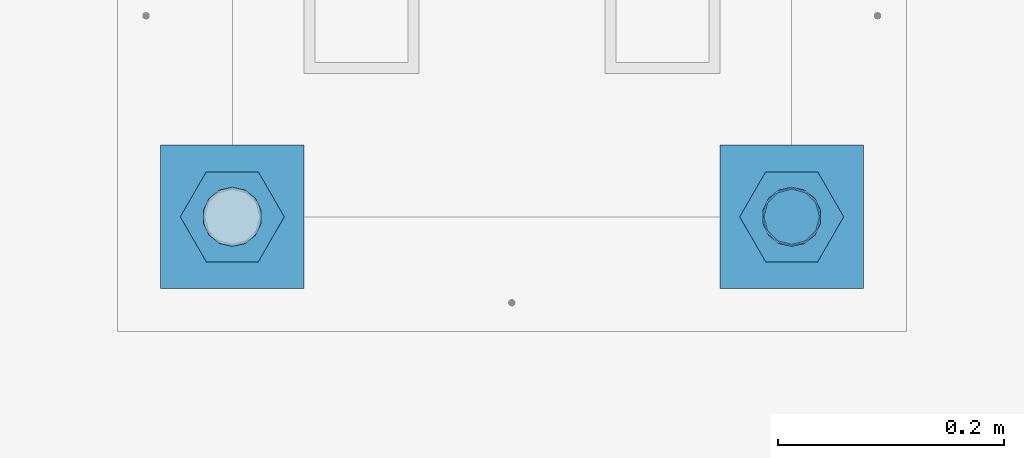
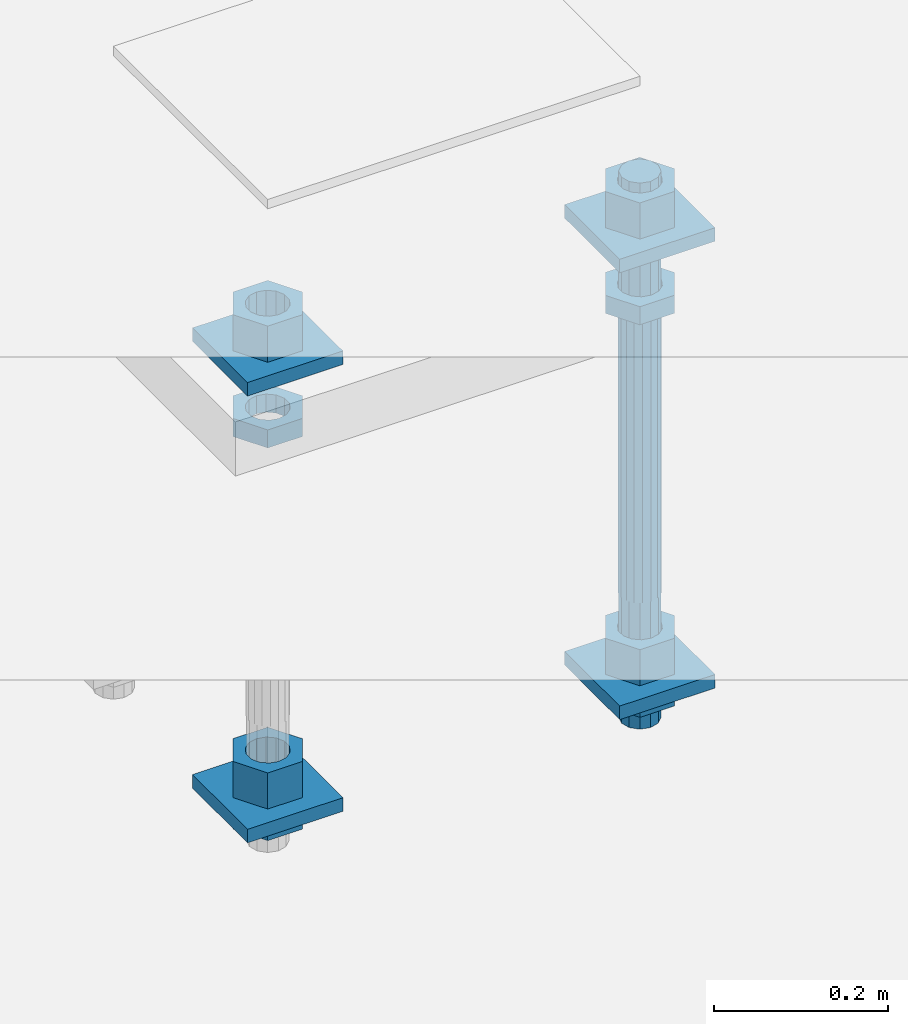
# One storey, part 2711 of 3843: 13 beams, 1 element without a shape of its own.
"""IFC2X3 building model written with IfcOpenShell, lengths in millimetres."""

import ifcopenshell
import ifcopenshell.guid

model = None  # the IFC model being written
_history = None  # IfcOwnerHistory: only IFC2X3 demands one
_inside = {}  # id of a spatial element -> (the spatial element, [elements in it])
_under = {}  # id of a project, library or spatial element -> (it, [spatial elements below it])
_declared = {}  # id of a project -> (the project, [libraries it declares])
_typed = {}  # id of a type object -> (the type object, [elements of that type])
_made_of = {}  # id of a material, layer set ... -> (it, [elements and type objects made of it])


def new_model(schema):
    """Start an empty IFC model of exactly this schema.

    Asked for "IFC4X3", IfcOpenShell would pick the latest addendum, in which some entities
    have other attributes; the version numbers below select the first issue.
    IFC2X3 requires an IfcOwnerHistory on every rooted entity: one is made here for all.
    """
    global model, _history
    if schema == "IFC4X3":
        model = ifcopenshell.file(schema_version=(4, 3, 0, 0))
    else:
        model = ifcopenshell.file(schema=schema)
    _inside.clear()
    _under.clear()
    _declared.clear()
    _typed.clear()
    _made_of.clear()
    _history = None
    if model.schema == "IFC2X3":
        org = make("IfcOrganization", Name="unknown")
        user = make(
            "IfcPersonAndOrganization",
            ThePerson=make("IfcPerson", FamilyName="unknown"),
            TheOrganization=org,
        )
        app = make(
            "IfcApplication",
            ApplicationDeveloper=org,
            Version="unknown",
            ApplicationFullName="unknown",
            ApplicationIdentifier="unknown",
        )
        _history = make(
            "IfcOwnerHistory",
            OwningUser=user,
            OwningApplication=app,
            ChangeAction="ADDED",
            CreationDate=0,
        )
    return model


def make(cls, **values):
    """One entity of the class cls with the attributes given. An attribute that is None is left unset."""
    return model.create_entity(
        cls, **{name: value for name, value in values.items() if value is not None}
    )


def rooted(cls, **values):
    """An entity with a GlobalId (a new one), such as an element, a storey or a relation."""
    return make(cls, GlobalId=ifcopenshell.guid.new(), OwnerHistory=_history, **values)


def si_unit(unit_type, name, prefix=None):
    """IfcSIUnit, for example si_unit("LENGTHUNIT", "METRE", prefix="MILLI")."""
    return make("IfcSIUnit", UnitType=unit_type, Prefix=prefix, Name=name)


def assignment(units):
    """IfcUnitAssignment: the units of a project."""
    return None if units is None else make("IfcUnitAssignment", Units=units)


def point(xyz):
    """IfcCartesianPoint."""
    return None if xyz is None else make("IfcCartesianPoint", Coordinates=xyz)


def direction(xyz):
    """IfcDirection."""
    return None if xyz is None else make("IfcDirection", DirectionRatios=xyz)


def frame(location, z_axis=None, x_axis=None):
    """IfcAxis2Placement3D, a coordinate frame: its origin and axes. An axis left out is left unset."""
    return make(
        "IfcAxis2Placement3D",
        Location=point(location),
        Axis=direction(z_axis),
        RefDirection=direction(x_axis),
    )


def origin_with_axes():
    """The frame at (0, 0, 0) with the z axis (0, 0, 1) and the x axis (1, 0, 0) written out."""
    return frame((0.0, 0.0, 0.0), z_axis=(0.0, 0.0, 1.0), x_axis=(1.0, 0.0, 0.0))


def place(relative_to, where):
    """IfcLocalPlacement: puts the frame where relative to a parent placement (None: the world)."""
    return make(
        "IfcLocalPlacement", PlacementRelTo=relative_to, RelativePlacement=where
    )


def context(
    kind, dimensions, precision=None, world=None, true_north=None, identifier=None
):
    """IfcGeometricRepresentationContext, for example the 3D "Model" context."""
    return make(
        "IfcGeometricRepresentationContext",
        ContextIdentifier=identifier,
        ContextType=kind,
        CoordinateSpaceDimension=dimensions,
        Precision=precision,
        WorldCoordinateSystem=world,
        TrueNorth=true_north,
    )


def subcontext(parent, identifier, kind, view, scale=None):
    """IfcGeometricRepresentationSubContext, for example "Body" below "Model"."""
    return make(
        "IfcGeometricRepresentationSubContext",
        ContextIdentifier=identifier,
        ContextType=kind,
        ParentContext=parent,
        TargetScale=scale,
        TargetView=view,
    )


def project(units=None, contexts=None):
    """IfcProject with its units and contexts."""
    return rooted(
        "IfcProject",
        Name="project",
        RepresentationContexts=contexts,
        UnitsInContext=assignment(units),
    )


def spatial(cls, under=None, at=None, **own):
    """A site, building, storey or space (cls), placed at a placement, below another one or the project."""
    s = rooted(cls, ObjectPlacement=at, **own)
    if under is not None:
        _under.setdefault(under.id(), (under, []))[1].append(s)
    return s


def faces_of(points, faces, orient=None, outer=None):
    """IfcFace entities. A face is a list of loops; a loop is a list of indices into points, from 0.

    orient and outer hold one flag for each loop. By default every Orientation is true, the
    first loop of a face is its IfcFaceOuterBound and the others are IfcFaceBound.
    """
    made = []
    for i, loops in enumerate(faces):
        bounds = []
        for j, loop in enumerate(loops):
            is_outer = j == 0 if outer is None else outer[i][j]
            bounds.append(
                make(
                    "IfcFaceOuterBound" if is_outer else "IfcFaceBound",
                    Bound=make("IfcPolyLoop", Polygon=[points[k] for k in loop]),
                    Orientation=True if orient is None else orient[i][j],
                )
            )
        made.append(make("IfcFace", Bounds=bounds))
    return made


def faceted_brep(points, faces, orient=None, outer=None, voids=None):
    """IfcFacetedBrep: a solid bounded by flat faces; with voids (closed shells), ...WithVoids."""
    shared = [point(p) for p in points]
    hull = make("IfcClosedShell", CfsFaces=faces_of(shared, faces, orient, outer))
    if voids is None:
        return make("IfcFacetedBrep", Outer=hull)
    return make(
        "IfcFacetedBrepWithVoids",
        Outer=hull,
        Voids=[
            make(cls, CfsFaces=faces_of(shared, fs, o, b)) for cls, fs, o, b in voids
        ],
    )


def shape(context_of_items, identifier, shape_type, items):
    """IfcShapeRepresentation: the items that make up one representation, for example the "Body"."""
    return make(
        "IfcShapeRepresentation",
        ContextOfItems=context_of_items,
        RepresentationIdentifier=identifier,
        RepresentationType=shape_type,
        Items=items,
    )


def material(Name=None, Category=None):
    """IfcMaterial."""
    return make("IfcMaterial", Name=Name, Category=Category)


def made_of(thing, what):
    """Note that an element or type object is made of a material, layer set ...; save() writes the relation."""
    if what is not None:
        _made_of.setdefault(what.id(), (what, []))[1].append(thing)
    return thing


def type_object(cls, material=None, **own):
    """A type object (cls), such as IfcWallType, which elements share."""
    return made_of(rooted(cls, **own), material)


def element(
    cls,
    number,
    at=None,
    inside=None,
    cuts=None,
    type_object=None,
    material=None,
    context=None,
    identifier="Body",
    shape_type=None,
    held_by="IfcProductDefinitionShape",
    body=None,
    shapes=None,
    **own,
):
    """One element of the class cls, such as IfcWall. Its Tag is "e" and its number.

    at: its placement. inside: the storey or other place that contains it. cuts: it is an
    opening in that element (IfcRelVoidsElement). A single representation is given by context,
    identifier, shape_type and body (its items); several are given by shapes. held_by: the class
    of the entity that holds the representations. save() writes the other relations.
    """
    e = rooted(cls, Tag="e%d" % number, ObjectPlacement=at, **own)
    if body is not None:
        shapes = [shape(context, identifier, shape_type, body)]
    if shapes is not None:
        e.Representation = make(held_by, Representations=shapes)
    if inside is not None:
        _inside.setdefault(inside.id(), (inside, []))[1].append(e)
    if cuts is not None:
        rooted(
            "IfcRelVoidsElement", RelatingBuildingElement=cuts, RelatedOpeningElement=e
        )
    if type_object is not None:
        _typed.setdefault(type_object.id(), (type_object, []))[1].append(e)
    return made_of(e, material)


def aggregate(whole, parts):
    """IfcRelAggregates: a whole, such as a stair, and the parts it consists of."""
    return rooted("IfcRelAggregates", RelatingObject=whole, RelatedObjects=parts)


def save(model, path):
    """Write the relations noted so far, then the file.

    IfcRelAggregates (storeys below a building ...), IfcRelContainedInSpatialStructure (elements
    in a storey), IfcRelDefinesByType, IfcRelAssociatesMaterial and IfcRelDeclares: one each for
    every whole, place, type object, material and project.
    """
    for whole, parts in _under.values():
        aggregate(whole, parts)
    for where, things in _inside.values():
        rooted(
            "IfcRelContainedInSpatialStructure",
            RelatedElements=things,
            RelatingStructure=where,
        )
    for kind, things in _typed.values():
        rooted("IfcRelDefinesByType", RelatedObjects=things, RelatingType=kind)
    for what, things in _made_of.values():
        rooted("IfcRelAssociatesMaterial", RelatedObjects=things, RelatingMaterial=what)
    for by, libraries in _declared.values():
        rooted("IfcRelDeclares", RelatingContext=by, RelatedDefinitions=libraries)
    model.write(path)


model = new_model("IFC2X3")

# Units and contexts
model_context = context("Model", 3, precision=1e-05, world=origin_with_axes())
body_context = subcontext(model_context, "Body", "Model", "MODEL_VIEW")
ifc_project = project(units=[si_unit("LENGTHUNIT", "METRE", prefix="MILLI"), si_unit("AREAUNIT", "SQUARE_METRE"), si_unit("VOLUMEUNIT", "CUBIC_METRE"), si_unit("MASSUNIT", "GRAM", prefix="KILO"), si_unit("TIMEUNIT", "SECOND"), si_unit("PLANEANGLEUNIT", "RADIAN"), si_unit("SOLIDANGLEUNIT", "STERADIAN"), si_unit("THERMODYNAMICTEMPERATUREUNIT", "DEGREE_CELSIUS"), si_unit("LUMINOUSINTENSITYUNIT", "LUMEN")], contexts=[model_context])

# Site, building, storey
site_placement = place(None, origin_with_axes())
site = spatial("IfcSite", under=ifc_project, at=site_placement, CompositionType="ELEMENT")
building_placement = place(site_placement, origin_with_axes())
building = spatial("IfcBuilding", under=site, at=building_placement, Name="Undefined", CompositionType="ELEMENT")
storey_placement = place(building_placement, origin_with_axes())
storey = spatial("IfcBuildingStorey", under=building, at=storey_placement, Name="Undefined", CompositionType="ELEMENT", Elevation=0.0)

# Assembly, beams
assembly_placement = place(storey_placement, origin_with_axes())
assembly = element("IfcElementAssembly", 1, at=assembly_placement, inside=storey, Name="TEMPLATE", AssemblyPlace="NOTDEFINED", PredefinedType="RIGID_FRAME")
ifc_material_1 = material(Name="STEEL/A572-50")
beam_type_1 = type_object("IfcBeamType", PredefinedType="NOTDEFINED")
beam_1_placement = place(assembly_placement, frame((105403.65, 48615.5999984741, 29873.575), z_axis=(-1.0, 0.0, 0.0), x_axis=(0.0, -1.0, 0.0)))
beam_1 = element("IfcBeam", 2, at=beam_1_placement, type_object=beam_type_1, material=ifc_material_1, Name="WASHER_PLATE", context=body_context, shape_type="Brep", body=[
    faceted_brep([(0.0, 9.52500000000146, -63.5), (0.0, 9.52500000000146, 63.5), (127.0, 9.52500000000146, 63.5), (127.0, 9.52500000000146, -63.5), (0.0, -9.52500000000146, 63.5), (127.0, -9.52500000000146, 63.5), (0.0, -9.52500000000146, -63.5), (127.0, -9.52500000000146, -63.5)], [[[0, 1, 2, 3]], [[1, 4, 5, 2]], [[4, 6, 7, 5]], [[6, 0, 3, 7]], [[5, 7, 3, 2]], [[6, 4, 1, 0]]]),
])
beam_2_placement = place(assembly_placement, frame((104908.35, 48615.5999984741, 29873.575), z_axis=(-1.0, 0.0, 0.0), x_axis=(0.0, -1.0, 0.0)))
beam_2 = element("IfcBeam", 3, at=beam_2_placement, type_object=beam_type_1, material=ifc_material_1, Name="WASHER_PLATE", context=body_context, shape_type="Brep", body=[
    faceted_brep([(0.0, 9.52500000000146, -63.5), (0.0, 9.52500000000146, 63.5), (127.0, 9.52500000000146, 63.5), (127.0, 9.52500000000146, -63.5), (0.0, -9.52500000000146, 63.5), (127.0, -9.52500000000146, 63.5), (0.0, -9.52500000000146, -63.5), (127.0, -9.52500000000146, -63.5)], [[[0, 1, 2, 3]], [[1, 4, 5, 2]], [[4, 6, 7, 5]], [[6, 0, 3, 7]], [[5, 7, 3, 2]], [[6, 4, 1, 0]]]),
])
beam_3_placement = place(assembly_placement, frame((105403.65, 48615.5999984741, 29244.925), z_axis=(-1.0, 0.0, 0.0), x_axis=(0.0, -1.0, 0.0)))
beam_3 = element("IfcBeam", 4, at=beam_3_placement, type_object=beam_type_1, material=ifc_material_1, Name="WASHER_PLATE", context=body_context, shape_type="Brep", body=[
    faceted_brep([(0.0, 9.52500000000146, -63.5), (0.0, 9.52500000000146, 63.5), (127.0, 9.52500000000146, 63.5), (127.0, 9.52500000000146, -63.5), (0.0, -9.52500000000146, 63.5), (127.0, -9.52500000000146, 63.5), (0.0, -9.52500000000146, -63.5), (127.0, -9.52500000000146, -63.5)], [[[0, 1, 2, 3]], [[1, 4, 5, 2]], [[4, 6, 7, 5]], [[6, 0, 3, 7]], [[5, 7, 3, 2]], [[6, 4, 1, 0]]]),
])
beam_4_placement = place(assembly_placement, frame((104908.35, 48615.5999984741, 29244.925), z_axis=(-1.0, 0.0, 0.0), x_axis=(0.0, -1.0, 0.0)))
beam_4 = element("IfcBeam", 5, at=beam_4_placement, type_object=beam_type_1, material=ifc_material_1, Name="WASHER_PLATE", context=body_context, shape_type="Brep", body=[
    faceted_brep([(0.0, 9.52500000000146, -63.5), (0.0, 9.52500000000146, 63.5), (127.0, 9.52500000000146, 63.5), (127.0, 9.52500000000146, -63.5), (0.0, -9.52500000000146, 63.5), (127.0, -9.52500000000146, 63.5), (0.0, -9.52500000000146, -63.5), (127.0, -9.52500000000146, -63.5)], [[[0, 1, 2, 3]], [[1, 4, 5, 2]], [[4, 6, 7, 5]], [[6, 0, 3, 7]], [[5, 7, 3, 2]], [[6, 4, 1, 0]]]),
])
ifc_material_2 = material(Name="STEEL/A36")
beam_type_2 = type_object("IfcBeamType", Name="2_HALF_NUT", PredefinedType="NOTDEFINED")
beam_5_placement = place(assembly_placement, frame((105403.65, 48552.0999984741, 29787.85), z_axis=(0.0, -1.0, 0.0), x_axis=(0.0, 0.0, -1.0)))
beam_5 = element("IfcBeam", 6, at=beam_5_placement, type_object=beam_type_2, material=ifc_material_2, Name="NUT", ObjectType="2_HALF_NUT", context=body_context, shape_type="Brep", body=[
    faceted_brep([(0.0, -46.0369987487793, 0.0), (0.0, -23.0184993743896, -39.869213104248), (25.4000000000015, -23.0184993743896, -39.869213104248), (25.4000000000015, -46.0369987487793, 0.0), (0.0, 23.0184993743896, -39.869213104248), (25.4000000000015, 23.0184993743896, -39.869213104248), (0.0, 46.0369987487793, 0.0), (25.4000000000015, 46.0369987487793, 0.0), (0.0, 23.0184993743896, 39.869213104248), (25.4000000000015, 23.0184993743896, 39.869213104248), (0.0, -23.0184993743896, 39.869213104248), (25.4000000000015, -23.0184993743896, 39.869213104248), (0.0, 0.0, 26.1940002441406), (0.0, 11.3650617044477, 23.5999013092805), (25.4000000000015, 11.3650617044477, 23.5999013092805), (25.4000000000015, 0.0, 26.1940002441406), (0.0, 20.4791109456419, 16.3316083006721), (25.4000000000015, 20.4791109456419, 16.3316083006721), (0.0, 25.5370200498292, 5.82867859874386), (25.4000000000015, 25.5370200498292, 5.82867859874386), (0.0, 25.5370200498292, -5.82867859874386), (25.4000000000015, 25.5370200498292, -5.82867859874386), (0.0, 20.4791109456419, -16.3316083006721), (25.4000000000015, 20.4791109456419, -16.3316083006721), (0.0, 11.3650617044477, -23.5999013092805), (25.4000000000015, 11.3650617044477, -23.5999013092805), (0.0, 0.0, -26.1940002441406), (25.4000000000015, 0.0, -26.1940002441406), (0.0, -11.3650617044477, -23.5999013092805), (25.4000000000015, -11.3650617044477, -23.5999013092805), (0.0, -20.4791109456419, -16.3316083006721), (25.4000000000015, -20.4791109456419, -16.3316083006721), (0.0, -25.5370200498292, -5.82867859874386), (25.4000000000015, -25.5370200498292, -5.82867859874386), (0.0, -25.5370200498292, 5.82867859874386), (25.4000000000015, -25.5370200498292, 5.82867859874386), (0.0, -20.4791109456419, 16.3316083006721), (25.4000000000015, -20.4791109456419, 16.3316083006721), (0.0, -11.3650617044477, 23.5999013092805), (25.4000000000015, -11.3650617044477, 23.5999013092805)], [[[0, 1, 2, 3]], [[1, 4, 5, 2]], [[4, 6, 7, 5]], [[6, 8, 9, 7]], [[8, 10, 11, 9]], [[10, 0, 3, 11]], [[12, 13, 14, 15]], [[13, 16, 17, 14]], [[16, 18, 19, 17]], [[18, 20, 21, 19]], [[20, 22, 23, 21]], [[22, 24, 25, 23]], [[24, 26, 27, 25]], [[26, 28, 29, 27]], [[28, 30, 31, 29]], [[30, 32, 33, 31]], [[32, 34, 35, 33]], [[34, 36, 37, 35]], [[36, 38, 39, 37]], [[38, 12, 15, 39]], [[5, 7, 9, 11, 3, 2], [17, 19, 21, 23, 25, 27, 29, 31, 33, 35, 37, 39, 15, 14]], [[10, 8, 6, 4, 1, 0], [38, 36, 34, 32, 30, 28, 26, 24, 22, 20, 18, 16, 13, 12]]]),
])
beam_6_placement = place(assembly_placement, frame((105403.65, 48552.0999984741, 29235.4), z_axis=(0.0, -1.0, 0.0), x_axis=(0.0, 0.0, -1.0)))
beam_6 = element("IfcBeam", 7, at=beam_6_placement, type_object=beam_type_2, material=ifc_material_2, Name="NUT", ObjectType="2_HALF_NUT", context=body_context, shape_type="Brep", body=[
    faceted_brep([(0.0, -46.0369987487793, 0.0), (0.0, -23.0184993743896, -39.869213104248), (25.4000000000015, -23.0184993743896, -39.869213104248), (25.4000000000015, -46.0369987487793, 0.0), (0.0, 23.0184993743896, -39.869213104248), (25.4000000000015, 23.0184993743896, -39.869213104248), (0.0, 46.0369987487793, 0.0), (25.4000000000015, 46.0369987487793, 0.0), (0.0, 23.0184993743896, 39.869213104248), (25.4000000000015, 23.0184993743896, 39.869213104248), (0.0, -23.0184993743896, 39.869213104248), (25.4000000000015, -23.0184993743896, 39.869213104248), (0.0, 0.0, 26.1940002441406), (0.0, 11.3650617044477, 23.5999013092805), (25.4000000000015, 11.3650617044477, 23.5999013092805), (25.4000000000015, 0.0, 26.1940002441406), (0.0, 20.4791109456419, 16.3316083006721), (25.4000000000015, 20.4791109456419, 16.3316083006721), (0.0, 25.5370200498292, 5.82867859874386), (25.4000000000015, 25.5370200498292, 5.82867859874386), (0.0, 25.5370200498292, -5.82867859874386), (25.4000000000015, 25.5370200498292, -5.82867859874386), (0.0, 20.4791109456419, -16.3316083006721), (25.4000000000015, 20.4791109456419, -16.3316083006721), (0.0, 11.3650617044477, -23.5999013092805), (25.4000000000015, 11.3650617044477, -23.5999013092805), (0.0, 0.0, -26.1940002441406), (25.4000000000015, 0.0, -26.1940002441406), (0.0, -11.3650617044477, -23.5999013092805), (25.4000000000015, -11.3650617044477, -23.5999013092805), (0.0, -20.4791109456419, -16.3316083006721), (25.4000000000015, -20.4791109456419, -16.3316083006721), (0.0, -25.5370200498292, -5.82867859874386), (25.4000000000015, -25.5370200498292, -5.82867859874386), (0.0, -25.5370200498292, 5.82867859874386), (25.4000000000015, -25.5370200498292, 5.82867859874386), (0.0, -20.4791109456419, 16.3316083006721), (25.4000000000015, -20.4791109456419, 16.3316083006721), (0.0, -11.3650617044477, 23.5999013092805), (25.4000000000015, -11.3650617044477, 23.5999013092805)], [[[0, 1, 2, 3]], [[1, 4, 5, 2]], [[4, 6, 7, 5]], [[6, 8, 9, 7]], [[8, 10, 11, 9]], [[10, 0, 3, 11]], [[12, 13, 14, 15]], [[13, 16, 17, 14]], [[16, 18, 19, 17]], [[18, 20, 21, 19]], [[20, 22, 23, 21]], [[22, 24, 25, 23]], [[24, 26, 27, 25]], [[26, 28, 29, 27]], [[28, 30, 31, 29]], [[30, 32, 33, 31]], [[32, 34, 35, 33]], [[34, 36, 37, 35]], [[36, 38, 39, 37]], [[38, 12, 15, 39]], [[5, 7, 9, 11, 3, 2], [17, 19, 21, 23, 25, 27, 29, 31, 33, 35, 37, 39, 15, 14]], [[10, 8, 6, 4, 1, 0], [38, 36, 34, 32, 30, 28, 26, 24, 22, 20, 18, 16, 13, 12]]]),
])
beam_7_placement = place(assembly_placement, frame((104908.35, 48552.0999984741, 29787.85), z_axis=(0.0, -1.0, 0.0), x_axis=(0.0, 0.0, -1.0)))
beam_7 = element("IfcBeam", 8, at=beam_7_placement, type_object=beam_type_2, material=ifc_material_2, Name="NUT", ObjectType="2_HALF_NUT", context=body_context, shape_type="Brep", body=[
    faceted_brep([(0.0, -46.0369987487793, 0.0), (0.0, -23.0184993743896, -39.869213104248), (25.4000000000015, -23.0184993743896, -39.869213104248), (25.4000000000015, -46.0369987487793, 0.0), (0.0, 23.0184993743896, -39.869213104248), (25.4000000000015, 23.0184993743896, -39.869213104248), (0.0, 46.0369987487793, 0.0), (25.4000000000015, 46.0369987487793, 0.0), (0.0, 23.0184993743896, 39.869213104248), (25.4000000000015, 23.0184993743896, 39.869213104248), (0.0, -23.0184993743896, 39.869213104248), (25.4000000000015, -23.0184993743896, 39.869213104248), (0.0, 0.0, 26.1940002441406), (0.0, 11.3650617044477, 23.5999013092805), (25.4000000000015, 11.3650617044477, 23.5999013092805), (25.4000000000015, 0.0, 26.1940002441406), (0.0, 20.4791109456419, 16.3316083006721), (25.4000000000015, 20.4791109456419, 16.3316083006721), (0.0, 25.5370200498292, 5.82867859874386), (25.4000000000015, 25.5370200498292, 5.82867859874386), (0.0, 25.5370200498292, -5.82867859874386), (25.4000000000015, 25.5370200498292, -5.82867859874386), (0.0, 20.4791109456419, -16.3316083006721), (25.4000000000015, 20.4791109456419, -16.3316083006721), (0.0, 11.3650617044477, -23.5999013092805), (25.4000000000015, 11.3650617044477, -23.5999013092805), (0.0, 0.0, -26.1940002441406), (25.4000000000015, 0.0, -26.1940002441406), (0.0, -11.3650617044477, -23.5999013092805), (25.4000000000015, -11.3650617044477, -23.5999013092805), (0.0, -20.4791109456419, -16.3316083006721), (25.4000000000015, -20.4791109456419, -16.3316083006721), (0.0, -25.5370200498292, -5.82867859874386), (25.4000000000015, -25.5370200498292, -5.82867859874386), (0.0, -25.5370200498292, 5.82867859874386), (25.4000000000015, -25.5370200498292, 5.82867859874386), (0.0, -20.4791109456419, 16.3316083006721), (25.4000000000015, -20.4791109456419, 16.3316083006721), (0.0, -11.3650617044477, 23.5999013092805), (25.4000000000015, -11.3650617044477, 23.5999013092805)], [[[0, 1, 2, 3]], [[1, 4, 5, 2]], [[4, 6, 7, 5]], [[6, 8, 9, 7]], [[8, 10, 11, 9]], [[10, 0, 3, 11]], [[12, 13, 14, 15]], [[13, 16, 17, 14]], [[16, 18, 19, 17]], [[18, 20, 21, 19]], [[20, 22, 23, 21]], [[22, 24, 25, 23]], [[24, 26, 27, 25]], [[26, 28, 29, 27]], [[28, 30, 31, 29]], [[30, 32, 33, 31]], [[32, 34, 35, 33]], [[34, 36, 37, 35]], [[36, 38, 39, 37]], [[38, 12, 15, 39]], [[5, 7, 9, 11, 3, 2], [17, 19, 21, 23, 25, 27, 29, 31, 33, 35, 37, 39, 15, 14]], [[10, 8, 6, 4, 1, 0], [38, 36, 34, 32, 30, 28, 26, 24, 22, 20, 18, 16, 13, 12]]]),
])
beam_8_placement = place(assembly_placement, frame((104908.35, 48552.0999984741, 29235.4), z_axis=(0.0, -1.0, 0.0), x_axis=(0.0, 0.0, -1.0)))
beam_8 = element("IfcBeam", 9, at=beam_8_placement, type_object=beam_type_2, material=ifc_material_2, Name="NUT", ObjectType="2_HALF_NUT", context=body_context, shape_type="Brep", body=[
    faceted_brep([(0.0, -46.0369987487793, 0.0), (0.0, -23.0184993743896, -39.869213104248), (25.4000000000015, -23.0184993743896, -39.869213104248), (25.4000000000015, -46.0369987487793, 0.0), (0.0, 23.0184993743896, -39.869213104248), (25.4000000000015, 23.0184993743896, -39.869213104248), (0.0, 46.0369987487793, 0.0), (25.4000000000015, 46.0369987487793, 0.0), (0.0, 23.0184993743896, 39.869213104248), (25.4000000000015, 23.0184993743896, 39.869213104248), (0.0, -23.0184993743896, 39.869213104248), (25.4000000000015, -23.0184993743896, 39.869213104248), (0.0, 0.0, 26.1940002441406), (0.0, 11.3650617044477, 23.5999013092805), (25.4000000000015, 11.3650617044477, 23.5999013092805), (25.4000000000015, 0.0, 26.1940002441406), (0.0, 20.4791109456419, 16.3316083006721), (25.4000000000015, 20.4791109456419, 16.3316083006721), (0.0, 25.5370200498292, 5.82867859874386), (25.4000000000015, 25.5370200498292, 5.82867859874386), (0.0, 25.5370200498292, -5.82867859874386), (25.4000000000015, 25.5370200498292, -5.82867859874386), (0.0, 20.4791109456419, -16.3316083006721), (25.4000000000015, 20.4791109456419, -16.3316083006721), (0.0, 11.3650617044477, -23.5999013092805), (25.4000000000015, 11.3650617044477, -23.5999013092805), (0.0, 0.0, -26.1940002441406), (25.4000000000015, 0.0, -26.1940002441406), (0.0, -11.3650617044477, -23.5999013092805), (25.4000000000015, -11.3650617044477, -23.5999013092805), (0.0, -20.4791109456419, -16.3316083006721), (25.4000000000015, -20.4791109456419, -16.3316083006721), (0.0, -25.5370200498292, -5.82867859874386), (25.4000000000015, -25.5370200498292, -5.82867859874386), (0.0, -25.5370200498292, 5.82867859874386), (25.4000000000015, -25.5370200498292, 5.82867859874386), (0.0, -20.4791109456419, 16.3316083006721), (25.4000000000015, -20.4791109456419, 16.3316083006721), (0.0, -11.3650617044477, 23.5999013092805), (25.4000000000015, -11.3650617044477, 23.5999013092805)], [[[0, 1, 2, 3]], [[1, 4, 5, 2]], [[4, 6, 7, 5]], [[6, 8, 9, 7]], [[8, 10, 11, 9]], [[10, 0, 3, 11]], [[12, 13, 14, 15]], [[13, 16, 17, 14]], [[16, 18, 19, 17]], [[18, 20, 21, 19]], [[20, 22, 23, 21]], [[22, 24, 25, 23]], [[24, 26, 27, 25]], [[26, 28, 29, 27]], [[28, 30, 31, 29]], [[30, 32, 33, 31]], [[32, 34, 35, 33]], [[34, 36, 37, 35]], [[36, 38, 39, 37]], [[38, 12, 15, 39]], [[5, 7, 9, 11, 3, 2], [17, 19, 21, 23, 25, 27, 29, 31, 33, 35, 37, 39, 15, 14]], [[10, 8, 6, 4, 1, 0], [38, 36, 34, 32, 30, 28, 26, 24, 22, 20, 18, 16, 13, 12]]]),
])
beam_type_3 = type_object("IfcBeamType", Name="2_HEAVY_HEX_NUT", PredefinedType="NOTDEFINED")
beam_9_placement = place(assembly_placement, frame((105403.65, 48552.0999984741, 29933.9), z_axis=(0.0, -1.0, 0.0), x_axis=(0.0, 0.0, -1.0)))
beam_9 = element("IfcBeam", 10, at=beam_9_placement, type_object=beam_type_3, material=ifc_material_2, Name="NUT", ObjectType="2_HEAVY_HEX_NUT", context=body_context, shape_type="Brep", body=[
    faceted_brep([(0.0, -46.0369987487793, 0.0), (0.0, -23.0184993743896, -39.869213104248), (50.7999999999993, -23.0184993743896, -39.869213104248), (50.7999999999993, -46.0369987487793, 0.0), (0.0, 23.0184993743896, -39.869213104248), (50.7999999999993, 23.0184993743896, -39.869213104248), (0.0, 46.0369987487793, 0.0), (50.7999999999993, 46.0369987487793, 0.0), (0.0, 23.0184993743896, 39.869213104248), (50.7999999999993, 23.0184993743896, 39.869213104248), (0.0, -23.0184993743896, 39.869213104248), (50.7999999999993, -23.0184993743896, 39.869213104248), (0.0, 0.0, 26.1940002441406), (0.0, 11.3650617044477, 23.5999013092805), (50.7999999999993, 11.3650617044477, 23.5999013092805), (50.7999999999993, 0.0, 26.1940002441406), (0.0, 20.4791109456419, 16.3316083006721), (50.7999999999993, 20.4791109456419, 16.3316083006721), (0.0, 25.5370200498292, 5.82867859874386), (50.7999999999993, 25.5370200498292, 5.82867859874386), (0.0, 25.5370200498292, -5.82867859874386), (50.7999999999993, 25.5370200498292, -5.82867859874386), (0.0, 20.4791109456419, -16.3316083006721), (50.7999999999993, 20.4791109456419, -16.3316083006721), (0.0, 11.3650617044477, -23.5999013092805), (50.7999999999993, 11.3650617044477, -23.5999013092805), (0.0, 0.0, -26.1940002441406), (50.7999999999993, 0.0, -26.1940002441406), (0.0, -11.3650617044477, -23.5999013092805), (50.7999999999993, -11.3650617044477, -23.5999013092805), (0.0, -20.4791109456419, -16.3316083006721), (50.7999999999993, -20.4791109456419, -16.3316083006721), (0.0, -25.5370200498292, -5.82867859874386), (50.7999999999993, -25.5370200498292, -5.82867859874386), (0.0, -25.5370200498292, 5.82867859874386), (50.7999999999993, -25.5370200498292, 5.82867859874386), (0.0, -20.4791109456419, 16.3316083006721), (50.7999999999993, -20.4791109456419, 16.3316083006721), (0.0, -11.3650617044477, 23.5999013092805), (50.7999999999993, -11.3650617044477, 23.5999013092805)], [[[0, 1, 2, 3]], [[1, 4, 5, 2]], [[4, 6, 7, 5]], [[6, 8, 9, 7]], [[8, 10, 11, 9]], [[10, 0, 3, 11]], [[12, 13, 14, 15]], [[13, 16, 17, 14]], [[16, 18, 19, 17]], [[18, 20, 21, 19]], [[20, 22, 23, 21]], [[22, 24, 25, 23]], [[24, 26, 27, 25]], [[26, 28, 29, 27]], [[28, 30, 31, 29]], [[30, 32, 33, 31]], [[32, 34, 35, 33]], [[34, 36, 37, 35]], [[36, 38, 39, 37]], [[38, 12, 15, 39]], [[5, 7, 9, 11, 3, 2], [17, 19, 21, 23, 25, 27, 29, 31, 33, 35, 37, 39, 15, 14]], [[10, 8, 6, 4, 1, 0], [38, 36, 34, 32, 30, 28, 26, 24, 22, 20, 18, 16, 13, 12]]]),
])
beam_10_placement = place(assembly_placement, frame((105403.65, 48552.0999984741, 29305.25), z_axis=(0.0, -1.0, 0.0), x_axis=(0.0, 0.0, -1.0)))
beam_10 = element("IfcBeam", 11, at=beam_10_placement, type_object=beam_type_3, material=ifc_material_2, Name="NUT", ObjectType="2_HEAVY_HEX_NUT", context=body_context, shape_type="Brep", body=[
    faceted_brep([(0.0, -46.0369987487793, 0.0), (0.0, -23.0184993743896, -39.869213104248), (50.7999999999993, -23.0184993743896, -39.869213104248), (50.7999999999993, -46.0369987487793, 0.0), (0.0, 23.0184993743896, -39.869213104248), (50.7999999999993, 23.0184993743896, -39.869213104248), (0.0, 46.0369987487793, 0.0), (50.7999999999993, 46.0369987487793, 0.0), (0.0, 23.0184993743896, 39.869213104248), (50.7999999999993, 23.0184993743896, 39.869213104248), (0.0, -23.0184993743896, 39.869213104248), (50.7999999999993, -23.0184993743896, 39.869213104248), (0.0, 0.0, 26.1940002441406), (0.0, 11.3650617044477, 23.5999013092805), (50.7999999999993, 11.3650617044477, 23.5999013092805), (50.7999999999993, 0.0, 26.1940002441406), (0.0, 20.4791109456419, 16.3316083006721), (50.7999999999993, 20.4791109456419, 16.3316083006721), (0.0, 25.5370200498292, 5.82867859874386), (50.7999999999993, 25.5370200498292, 5.82867859874386), (0.0, 25.5370200498292, -5.82867859874386), (50.7999999999993, 25.5370200498292, -5.82867859874386), (0.0, 20.4791109456419, -16.3316083006721), (50.7999999999993, 20.4791109456419, -16.3316083006721), (0.0, 11.3650617044477, -23.5999013092805), (50.7999999999993, 11.3650617044477, -23.5999013092805), (0.0, 0.0, -26.1940002441406), (50.7999999999993, 0.0, -26.1940002441406), (0.0, -11.3650617044477, -23.5999013092805), (50.7999999999993, -11.3650617044477, -23.5999013092805), (0.0, -20.4791109456419, -16.3316083006721), (50.7999999999993, -20.4791109456419, -16.3316083006721), (0.0, -25.5370200498292, -5.82867859874386), (50.7999999999993, -25.5370200498292, -5.82867859874386), (0.0, -25.5370200498292, 5.82867859874386), (50.7999999999993, -25.5370200498292, 5.82867859874386), (0.0, -20.4791109456419, 16.3316083006721), (50.7999999999993, -20.4791109456419, 16.3316083006721), (0.0, -11.3650617044477, 23.5999013092805), (50.7999999999993, -11.3650617044477, 23.5999013092805)], [[[0, 1, 2, 3]], [[1, 4, 5, 2]], [[4, 6, 7, 5]], [[6, 8, 9, 7]], [[8, 10, 11, 9]], [[10, 0, 3, 11]], [[12, 13, 14, 15]], [[13, 16, 17, 14]], [[16, 18, 19, 17]], [[18, 20, 21, 19]], [[20, 22, 23, 21]], [[22, 24, 25, 23]], [[24, 26, 27, 25]], [[26, 28, 29, 27]], [[28, 30, 31, 29]], [[30, 32, 33, 31]], [[32, 34, 35, 33]], [[34, 36, 37, 35]], [[36, 38, 39, 37]], [[38, 12, 15, 39]], [[5, 7, 9, 11, 3, 2], [17, 19, 21, 23, 25, 27, 29, 31, 33, 35, 37, 39, 15, 14]], [[10, 8, 6, 4, 1, 0], [38, 36, 34, 32, 30, 28, 26, 24, 22, 20, 18, 16, 13, 12]]]),
])
beam_11_placement = place(assembly_placement, frame((104908.35, 48552.0999984741, 29933.9), z_axis=(0.0, -1.0, 0.0), x_axis=(0.0, 0.0, -1.0)))
beam_11 = element("IfcBeam", 12, at=beam_11_placement, type_object=beam_type_3, material=ifc_material_2, Name="NUT", ObjectType="2_HEAVY_HEX_NUT", context=body_context, shape_type="Brep", body=[
    faceted_brep([(0.0, -46.0369987487793, 0.0), (0.0, -23.0184993743896, -39.869213104248), (50.7999999999993, -23.0184993743896, -39.869213104248), (50.7999999999993, -46.0369987487793, 0.0), (0.0, 23.0184993743896, -39.869213104248), (50.7999999999993, 23.0184993743896, -39.869213104248), (0.0, 46.0369987487793, 0.0), (50.7999999999993, 46.0369987487793, 0.0), (0.0, 23.0184993743896, 39.869213104248), (50.7999999999993, 23.0184993743896, 39.869213104248), (0.0, -23.0184993743896, 39.869213104248), (50.7999999999993, -23.0184993743896, 39.869213104248), (0.0, 0.0, 26.1940002441406), (0.0, 11.3650617044477, 23.5999013092805), (50.7999999999993, 11.3650617044477, 23.5999013092805), (50.7999999999993, 0.0, 26.1940002441406), (0.0, 20.4791109456419, 16.3316083006721), (50.7999999999993, 20.4791109456419, 16.3316083006721), (0.0, 25.5370200498292, 5.82867859874386), (50.7999999999993, 25.5370200498292, 5.82867859874386), (0.0, 25.5370200498292, -5.82867859874386), (50.7999999999993, 25.5370200498292, -5.82867859874386), (0.0, 20.4791109456419, -16.3316083006721), (50.7999999999993, 20.4791109456419, -16.3316083006721), (0.0, 11.3650617044477, -23.5999013092805), (50.7999999999993, 11.3650617044477, -23.5999013092805), (0.0, 0.0, -26.1940002441406), (50.7999999999993, 0.0, -26.1940002441406), (0.0, -11.3650617044477, -23.5999013092805), (50.7999999999993, -11.3650617044477, -23.5999013092805), (0.0, -20.4791109456419, -16.3316083006721), (50.7999999999993, -20.4791109456419, -16.3316083006721), (0.0, -25.5370200498292, -5.82867859874386), (50.7999999999993, -25.5370200498292, -5.82867859874386), (0.0, -25.5370200498292, 5.82867859874386), (50.7999999999993, -25.5370200498292, 5.82867859874386), (0.0, -20.4791109456419, 16.3316083006721), (50.7999999999993, -20.4791109456419, 16.3316083006721), (0.0, -11.3650617044477, 23.5999013092805), (50.7999999999993, -11.3650617044477, 23.5999013092805)], [[[0, 1, 2, 3]], [[1, 4, 5, 2]], [[4, 6, 7, 5]], [[6, 8, 9, 7]], [[8, 10, 11, 9]], [[10, 0, 3, 11]], [[12, 13, 14, 15]], [[13, 16, 17, 14]], [[16, 18, 19, 17]], [[18, 20, 21, 19]], [[20, 22, 23, 21]], [[22, 24, 25, 23]], [[24, 26, 27, 25]], [[26, 28, 29, 27]], [[28, 30, 31, 29]], [[30, 32, 33, 31]], [[32, 34, 35, 33]], [[34, 36, 37, 35]], [[36, 38, 39, 37]], [[38, 12, 15, 39]], [[5, 7, 9, 11, 3, 2], [17, 19, 21, 23, 25, 27, 29, 31, 33, 35, 37, 39, 15, 14]], [[10, 8, 6, 4, 1, 0], [38, 36, 34, 32, 30, 28, 26, 24, 22, 20, 18, 16, 13, 12]]]),
])
beam_12_placement = place(assembly_placement, frame((104908.35, 48552.0999984741, 29305.25), z_axis=(0.0, -1.0, 0.0), x_axis=(0.0, 0.0, -1.0)))
beam_12 = element("IfcBeam", 13, at=beam_12_placement, type_object=beam_type_3, material=ifc_material_2, Name="NUT", ObjectType="2_HEAVY_HEX_NUT", context=body_context, shape_type="Brep", body=[
    faceted_brep([(0.0, -46.0369987487793, 0.0), (0.0, -23.0184993743896, -39.869213104248), (50.7999999999993, -23.0184993743896, -39.869213104248), (50.7999999999993, -46.0369987487793, 0.0), (0.0, 23.0184993743896, -39.869213104248), (50.7999999999993, 23.0184993743896, -39.869213104248), (0.0, 46.0369987487793, 0.0), (50.7999999999993, 46.0369987487793, 0.0), (0.0, 23.0184993743896, 39.869213104248), (50.7999999999993, 23.0184993743896, 39.869213104248), (0.0, -23.0184993743896, 39.869213104248), (50.7999999999993, -23.0184993743896, 39.869213104248), (0.0, 0.0, 26.1940002441406), (0.0, 11.3650617044477, 23.5999013092805), (50.7999999999993, 11.3650617044477, 23.5999013092805), (50.7999999999993, 0.0, 26.1940002441406), (0.0, 20.4791109456419, 16.3316083006721), (50.7999999999993, 20.4791109456419, 16.3316083006721), (0.0, 25.5370200498292, 5.82867859874386), (50.7999999999993, 25.5370200498292, 5.82867859874386), (0.0, 25.5370200498292, -5.82867859874386), (50.7999999999993, 25.5370200498292, -5.82867859874386), (0.0, 20.4791109456419, -16.3316083006721), (50.7999999999993, 20.4791109456419, -16.3316083006721), (0.0, 11.3650617044477, -23.5999013092805), (50.7999999999993, 11.3650617044477, -23.5999013092805), (0.0, 0.0, -26.1940002441406), (50.7999999999993, 0.0, -26.1940002441406), (0.0, -11.3650617044477, -23.5999013092805), (50.7999999999993, -11.3650617044477, -23.5999013092805), (0.0, -20.4791109456419, -16.3316083006721), (50.7999999999993, -20.4791109456419, -16.3316083006721), (0.0, -25.5370200498292, -5.82867859874386), (50.7999999999993, -25.5370200498292, -5.82867859874386), (0.0, -25.5370200498292, 5.82867859874386), (50.7999999999993, -25.5370200498292, 5.82867859874386), (0.0, -20.4791109456419, 16.3316083006721), (50.7999999999993, -20.4791109456419, 16.3316083006721), (0.0, -11.3650617044477, 23.5999013092805), (50.7999999999993, -11.3650617044477, 23.5999013092805)], [[[0, 1, 2, 3]], [[1, 4, 5, 2]], [[4, 6, 7, 5]], [[6, 8, 9, 7]], [[8, 10, 11, 9]], [[10, 0, 3, 11]], [[12, 13, 14, 15]], [[13, 16, 17, 14]], [[16, 18, 19, 17]], [[18, 20, 21, 19]], [[20, 22, 23, 21]], [[22, 24, 25, 23]], [[24, 26, 27, 25]], [[26, 28, 29, 27]], [[28, 30, 31, 29]], [[30, 32, 33, 31]], [[32, 34, 35, 33]], [[34, 36, 37, 35]], [[36, 38, 39, 37]], [[38, 12, 15, 39]], [[5, 7, 9, 11, 3, 2], [17, 19, 21, 23, 25, 27, 29, 31, 33, 35, 37, 39, 15, 14]], [[10, 8, 6, 4, 1, 0], [38, 36, 34, 32, 30, 28, 26, 24, 22, 20, 18, 16, 13, 12]]]),
])
ifc_material_3 = material()
beam_type_4 = type_object("IfcBeamType", PredefinedType="NOTDEFINED")
beam_13_placement = place(assembly_placement, frame((105403.65, 48552.0999984741, 29762.45), z_axis=(0.0, -1.0, 0.0), x_axis=(0.0, 0.0, -1.0)))
beam_13 = element("IfcBeam", 14, at=beam_13_placement, type_object=beam_type_4, material=ifc_material_3, Name="ANCHOR_ROD", context=body_context, shape_type="Brep", body=[
    faceted_brep([(-184.150000000001, -21.217622392709, 12.25), (-184.150000000001, -12.2499999999854, 21.2176223927163), (-184.150000000001, 1.45519152283669e-11, 24.5), (-184.150000000001, 12.2500000000146, 21.2176223927163), (-184.150000000001, 21.2176223927381, 12.25), (-184.150000000001, 24.5000000000146, 0.0), (-184.150000000001, 21.2176223927381, -12.25), (-184.150000000001, 12.2500000000146, -21.2176223927163), (-184.150000000001, 1.45519152283669e-11, -24.5), (-184.150000000001, -12.2499999999854, -21.2176223927163), (-184.150000000001, -21.217622392709, -12.25), (-184.150000000001, -24.4999999999854, 0.0), (0.0, 24.5000000000146, 0.0), (0.0, 21.2176223927381, -12.25), (0.0, 12.2500000000146, -21.2176223927163), (0.0, 1.45519152283669e-11, -24.5), (0.0, -12.2499999999854, -21.2176223927163), (0.0, -21.217622392709, -12.25), (0.0, -24.4999999999854, 0.0), (0.0, -21.217622392709, 12.25), (0.0, -12.2499999999854, 21.2176223927163), (0.0, 1.45519152283669e-11, 24.5), (0.0, 12.2500000000146, 21.2176223927163), (0.0, 21.2176223927381, 12.25), (0.0, -23.4665401257807, 9.72015918207035), (0.0, -17.9605122421344, 17.9605122421417), (0.0, -9.72015918207762, 23.466540125788), (0.0, 0.0, 25.4000000000015), (0.0, 9.72015918207762, 23.466540125788), (0.0, 17.9605122421344, 17.9605122421417), (0.0, 23.4665401257807, 9.72015918207035), (0.0, 25.3999996185303, 0.0), (0.0, 23.4665401257807, -9.72015918207035), (0.0, 17.9605122421344, -17.9605122421417), (0.0, 9.72015918207762, -23.466540125788), (0.0, 0.0, -25.4000000000015), (0.0, -9.72015918207762, -23.466540125788), (0.0, -17.9605122421344, -17.9605122421417), (0.0, -23.4665401257807, -9.72015918207035), (0.0, -25.3999996185303, 0.0), (406.399999999998, -25.3999999999942, 0.0), (406.399999999998, -23.4665401257807, 9.72015918207035), (406.399999999998, -17.9605122421344, 17.9605122421417), (406.399999999998, -9.72015918207762, 23.466540125788), (406.399999999998, 0.0, 25.4000000000015), (406.399999999998, 9.72015918207762, 23.466540125788), (406.399999999998, 17.9605122421344, 17.9605122421417), (406.399999999998, 23.4665401257807, 9.72015918207035), (406.399999999998, 25.3999999999942, 0.0), (406.399999999998, 23.4665401257807, -9.72015918207035), (406.399999999998, 17.9605122421344, -17.9605122421417), (406.399999999998, 9.72015918207762, -23.466540125788), (406.399999999998, 0.0, -25.4000000000015), (406.399999999998, -9.72015918207762, -23.466540125788), (406.399999999998, -17.9605122421344, -17.9605122421417), (406.399999999998, -23.4665401257807, -9.72015918207035), (406.399999999998, -12.2499999999854, 21.2176223927163), (406.399999999998, 1.45519152283669e-11, 24.5), (406.399999999998, 12.2500000000146, 21.2176223927163), (406.399999999998, 21.2176223927381, 12.25), (406.399999999998, 24.5000000000146, 0.0), (406.399999999998, 21.2176223927381, -12.25), (406.399999999998, 12.2500000000146, -21.2176223927163), (406.399999999998, 1.45519152283669e-11, -24.5), (406.399999999998, -12.2499999999854, -21.2176223927163), (406.399999999998, -21.217622392709, -12.25), (406.399999999998, -24.4999999999854, 0.0), (406.399999999998, -21.217622392709, 12.25), (584.200000000001, -12.2499999999854, -21.2176223927163), (584.200000000001, 1.45519152283669e-11, -24.5), (584.200000000001, 12.2500000000146, -21.2176223927163), (584.200000000001, 21.2176223927381, -12.25), (584.200000000001, 24.5000000000146, 0.0), (584.200000000001, 21.2176223927381, 12.25), (584.200000000001, 12.2500000000146, 21.2176223927163), (584.200000000001, 1.45519152283669e-11, 24.5), (584.200000000001, -12.2499999999854, 21.2176223927163), (584.200000000001, -21.217622392709, 12.25), (584.200000000001, -24.4999999999854, 0.0), (584.200000000001, -21.217622392709, -12.25)], [[[0, 1, 2, 3, 4, 5, 6, 7, 8, 9, 10, 11]], [[6, 5, 12, 13]], [[7, 6, 13, 14]], [[8, 7, 14, 15]], [[9, 8, 15, 16]], [[10, 9, 16, 17]], [[11, 10, 17, 18]], [[0, 11, 18, 19]], [[1, 0, 19, 20]], [[2, 1, 20, 21]], [[3, 2, 21, 22]], [[4, 3, 22, 23]], [[5, 4, 23, 12]], [[24, 25, 26, 27, 28, 29, 30, 31, 32, 33, 34, 35, 36, 37, 38, 39], [22, 21, 20, 19, 18, 17, 16, 15, 14, 13, 12, 23]], [[24, 39, 40, 41]], [[25, 24, 41, 42]], [[26, 25, 42, 43]], [[27, 26, 43, 44]], [[28, 27, 44, 45]], [[29, 28, 45, 46]], [[30, 29, 46, 47]], [[31, 30, 47, 48]], [[32, 31, 48, 49]], [[33, 32, 49, 50]], [[34, 33, 50, 51]], [[35, 34, 51, 52]], [[36, 35, 52, 53]], [[37, 36, 53, 54]], [[38, 37, 54, 55]], [[39, 38, 55, 40]], [[54, 53, 52, 51, 50, 49, 48, 47, 46, 45, 44, 43, 42, 41, 40, 55], [56, 57, 58, 59, 60, 61, 62, 63, 64, 65, 66, 67]], [[68, 69, 70, 71, 72, 73, 74, 75, 76, 77, 78, 79]], [[76, 75, 57, 56]], [[77, 76, 56, 67]], [[78, 77, 67, 66]], [[79, 78, 66, 65]], [[68, 79, 65, 64]], [[69, 68, 64, 63]], [[70, 69, 63, 62]], [[71, 70, 62, 61]], [[72, 71, 61, 60]], [[73, 72, 60, 59]], [[74, 73, 59, 58]], [[75, 74, 58, 57]]]),
])
aggregate(assembly, [beam_1, beam_2, beam_5, beam_9, beam_10, beam_6, beam_3, beam_13, beam_7, beam_11, beam_12, beam_8, beam_4])

save(model, "model.ifc")
